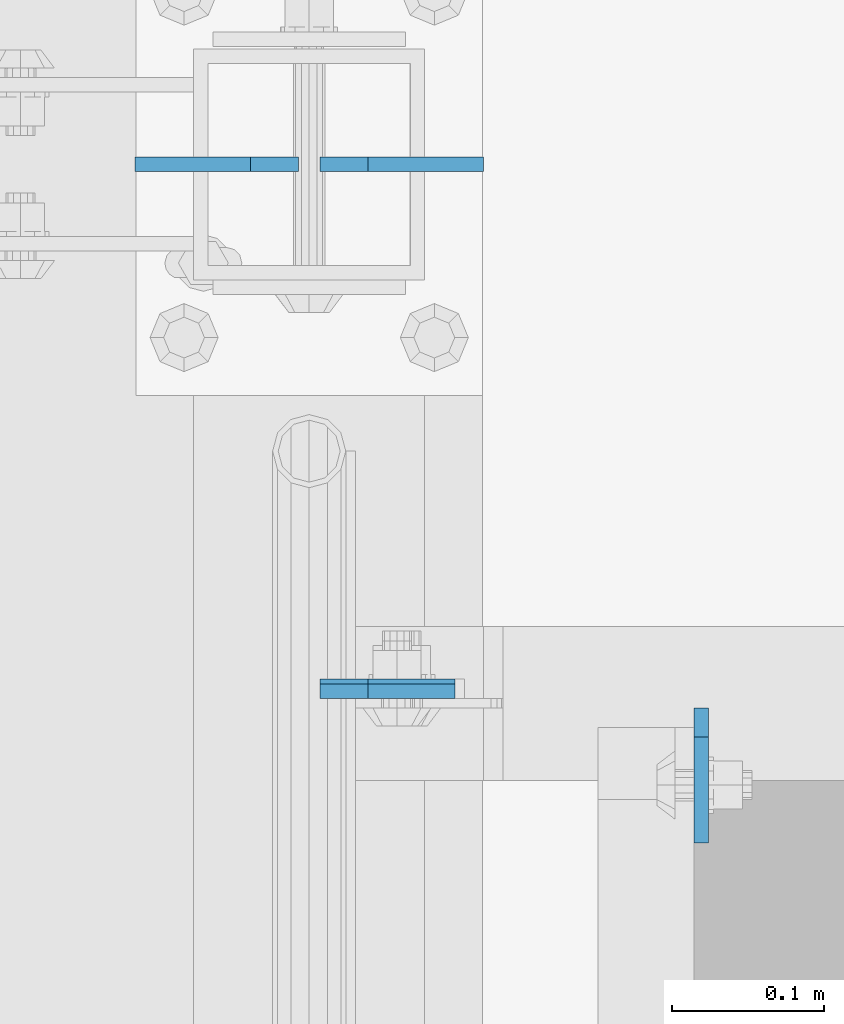
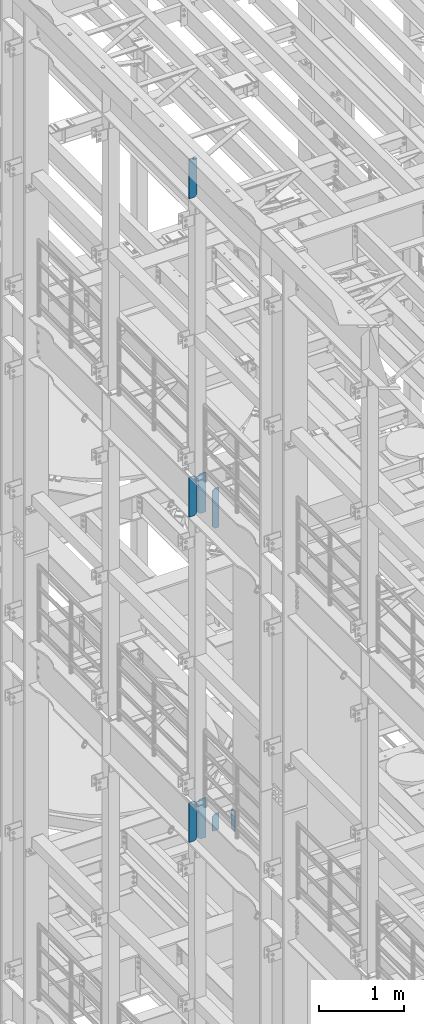
# One storey, part 1600 of 1876: 8 plates, 4 elements without a shape of their own.
"""IFC2X3 building model written with IfcOpenShell, lengths in millimetres."""

import ifcopenshell
import ifcopenshell.guid

model = None  # the IFC model being written
_history = None  # IfcOwnerHistory: only IFC2X3 demands one
_inside = {}  # id of a spatial element -> (the spatial element, [elements in it])
_under = {}  # id of a project, library or spatial element -> (it, [spatial elements below it])
_declared = {}  # id of a project -> (the project, [libraries it declares])
_typed = {}  # id of a type object -> (the type object, [elements of that type])
_made_of = {}  # id of a material, layer set ... -> (it, [elements and type objects made of it])


def new_model(schema):
    """Start an empty IFC model of exactly this schema.

    Asked for "IFC4X3", IfcOpenShell would pick the latest addendum, in which some entities
    have other attributes; the version numbers below select the first issue.
    IFC2X3 requires an IfcOwnerHistory on every rooted entity: one is made here for all.
    """
    global model, _history
    if schema == "IFC4X3":
        model = ifcopenshell.file(schema_version=(4, 3, 0, 0))
    else:
        model = ifcopenshell.file(schema=schema)
    _inside.clear()
    _under.clear()
    _declared.clear()
    _typed.clear()
    _made_of.clear()
    _history = None
    if model.schema == "IFC2X3":
        org = make("IfcOrganization", Name="unknown")
        user = make(
            "IfcPersonAndOrganization",
            ThePerson=make("IfcPerson", FamilyName="unknown"),
            TheOrganization=org,
        )
        app = make(
            "IfcApplication",
            ApplicationDeveloper=org,
            Version="unknown",
            ApplicationFullName="unknown",
            ApplicationIdentifier="unknown",
        )
        _history = make(
            "IfcOwnerHistory",
            OwningUser=user,
            OwningApplication=app,
            ChangeAction="ADDED",
            CreationDate=0,
        )
    return model


def make(cls, **values):
    """One entity of the class cls with the attributes given. An attribute that is None is left unset."""
    return model.create_entity(
        cls, **{name: value for name, value in values.items() if value is not None}
    )


def rooted(cls, **values):
    """An entity with a GlobalId (a new one), such as an element, a storey or a relation."""
    return make(cls, GlobalId=ifcopenshell.guid.new(), OwnerHistory=_history, **values)


def si_unit(unit_type, name, prefix=None):
    """IfcSIUnit, for example si_unit("LENGTHUNIT", "METRE", prefix="MILLI")."""
    return make("IfcSIUnit", UnitType=unit_type, Prefix=prefix, Name=name)


def assignment(units):
    """IfcUnitAssignment: the units of a project."""
    return None if units is None else make("IfcUnitAssignment", Units=units)


def point(xyz):
    """IfcCartesianPoint."""
    return None if xyz is None else make("IfcCartesianPoint", Coordinates=xyz)


def direction(xyz):
    """IfcDirection."""
    return None if xyz is None else make("IfcDirection", DirectionRatios=xyz)


def frame(location, z_axis=None, x_axis=None):
    """IfcAxis2Placement3D, a coordinate frame: its origin and axes. An axis left out is left unset."""
    return make(
        "IfcAxis2Placement3D",
        Location=point(location),
        Axis=direction(z_axis),
        RefDirection=direction(x_axis),
    )


def origin_with_axes():
    """The frame at (0, 0, 0) with the z axis (0, 0, 1) and the x axis (1, 0, 0) written out."""
    return frame((0.0, 0.0, 0.0), z_axis=(0.0, 0.0, 1.0), x_axis=(1.0, 0.0, 0.0))


def place(relative_to, where):
    """IfcLocalPlacement: puts the frame where relative to a parent placement (None: the world)."""
    return make(
        "IfcLocalPlacement", PlacementRelTo=relative_to, RelativePlacement=where
    )


def context(
    kind, dimensions, precision=None, world=None, true_north=None, identifier=None
):
    """IfcGeometricRepresentationContext, for example the 3D "Model" context."""
    return make(
        "IfcGeometricRepresentationContext",
        ContextIdentifier=identifier,
        ContextType=kind,
        CoordinateSpaceDimension=dimensions,
        Precision=precision,
        WorldCoordinateSystem=world,
        TrueNorth=true_north,
    )


def subcontext(parent, identifier, kind, view, scale=None):
    """IfcGeometricRepresentationSubContext, for example "Body" below "Model"."""
    return make(
        "IfcGeometricRepresentationSubContext",
        ContextIdentifier=identifier,
        ContextType=kind,
        ParentContext=parent,
        TargetScale=scale,
        TargetView=view,
    )


def project(units=None, contexts=None):
    """IfcProject with its units and contexts."""
    return rooted(
        "IfcProject",
        Name="project",
        RepresentationContexts=contexts,
        UnitsInContext=assignment(units),
    )


def spatial(cls, under=None, at=None, **own):
    """A site, building, storey or space (cls), placed at a placement, below another one or the project."""
    s = rooted(cls, ObjectPlacement=at, **own)
    if under is not None:
        _under.setdefault(under.id(), (under, []))[1].append(s)
    return s


def faces_of(points, faces, orient=None, outer=None):
    """IfcFace entities. A face is a list of loops; a loop is a list of indices into points, from 0.

    orient and outer hold one flag for each loop. By default every Orientation is true, the
    first loop of a face is its IfcFaceOuterBound and the others are IfcFaceBound.
    """
    made = []
    for i, loops in enumerate(faces):
        bounds = []
        for j, loop in enumerate(loops):
            is_outer = j == 0 if outer is None else outer[i][j]
            bounds.append(
                make(
                    "IfcFaceOuterBound" if is_outer else "IfcFaceBound",
                    Bound=make("IfcPolyLoop", Polygon=[points[k] for k in loop]),
                    Orientation=True if orient is None else orient[i][j],
                )
            )
        made.append(make("IfcFace", Bounds=bounds))
    return made


def faceted_brep(points, faces, orient=None, outer=None, voids=None):
    """IfcFacetedBrep: a solid bounded by flat faces; with voids (closed shells), ...WithVoids."""
    shared = [point(p) for p in points]
    hull = make("IfcClosedShell", CfsFaces=faces_of(shared, faces, orient, outer))
    if voids is None:
        return make("IfcFacetedBrep", Outer=hull)
    return make(
        "IfcFacetedBrepWithVoids",
        Outer=hull,
        Voids=[
            make(cls, CfsFaces=faces_of(shared, fs, o, b)) for cls, fs, o, b in voids
        ],
    )


def shape(context_of_items, identifier, shape_type, items):
    """IfcShapeRepresentation: the items that make up one representation, for example the "Body"."""
    return make(
        "IfcShapeRepresentation",
        ContextOfItems=context_of_items,
        RepresentationIdentifier=identifier,
        RepresentationType=shape_type,
        Items=items,
    )


def material(Name=None, Category=None):
    """IfcMaterial."""
    return make("IfcMaterial", Name=Name, Category=Category)


def made_of(thing, what):
    """Note that an element or type object is made of a material, layer set ...; save() writes the relation."""
    if what is not None:
        _made_of.setdefault(what.id(), (what, []))[1].append(thing)
    return thing


def type_object(cls, material=None, **own):
    """A type object (cls), such as IfcWallType, which elements share."""
    return made_of(rooted(cls, **own), material)


def element(
    cls,
    number,
    at=None,
    inside=None,
    cuts=None,
    type_object=None,
    material=None,
    context=None,
    identifier="Body",
    shape_type=None,
    held_by="IfcProductDefinitionShape",
    body=None,
    shapes=None,
    **own,
):
    """One element of the class cls, such as IfcWall. Its Tag is "e" and its number.

    at: its placement. inside: the storey or other place that contains it. cuts: it is an
    opening in that element (IfcRelVoidsElement). A single representation is given by context,
    identifier, shape_type and body (its items); several are given by shapes. held_by: the class
    of the entity that holds the representations. save() writes the other relations.
    """
    e = rooted(cls, Tag="e%d" % number, ObjectPlacement=at, **own)
    if body is not None:
        shapes = [shape(context, identifier, shape_type, body)]
    if shapes is not None:
        e.Representation = make(held_by, Representations=shapes)
    if inside is not None:
        _inside.setdefault(inside.id(), (inside, []))[1].append(e)
    if cuts is not None:
        rooted(
            "IfcRelVoidsElement", RelatingBuildingElement=cuts, RelatedOpeningElement=e
        )
    if type_object is not None:
        _typed.setdefault(type_object.id(), (type_object, []))[1].append(e)
    return made_of(e, material)


def aggregate(whole, parts):
    """IfcRelAggregates: a whole, such as a stair, and the parts it consists of."""
    return rooted("IfcRelAggregates", RelatingObject=whole, RelatedObjects=parts)


def save(model, path):
    """Write the relations noted so far, then the file.

    IfcRelAggregates (storeys below a building ...), IfcRelContainedInSpatialStructure (elements
    in a storey), IfcRelDefinesByType, IfcRelAssociatesMaterial and IfcRelDeclares: one each for
    every whole, place, type object, material and project.
    """
    for whole, parts in _under.values():
        aggregate(whole, parts)
    for where, things in _inside.values():
        rooted(
            "IfcRelContainedInSpatialStructure",
            RelatedElements=things,
            RelatingStructure=where,
        )
    for kind, things in _typed.values():
        rooted("IfcRelDefinesByType", RelatedObjects=things, RelatingType=kind)
    for what, things in _made_of.values():
        rooted("IfcRelAssociatesMaterial", RelatedObjects=things, RelatingMaterial=what)
    for by, libraries in _declared.values():
        rooted("IfcRelDeclares", RelatingContext=by, RelatedDefinitions=libraries)
    model.write(path)


model = new_model("IFC2X3")

# Units and contexts
model_context = context("Model", 3, precision=1e-05, world=origin_with_axes())
body_context = subcontext(model_context, "Body", "Model", "MODEL_VIEW")
ifc_project = project(units=[si_unit("LENGTHUNIT", "METRE", prefix="MILLI"), si_unit("AREAUNIT", "SQUARE_METRE"), si_unit("VOLUMEUNIT", "CUBIC_METRE"), si_unit("MASSUNIT", "GRAM", prefix="KILO"), si_unit("TIMEUNIT", "SECOND"), si_unit("PLANEANGLEUNIT", "RADIAN"), si_unit("SOLIDANGLEUNIT", "STERADIAN"), si_unit("THERMODYNAMICTEMPERATUREUNIT", "DEGREE_CELSIUS"), si_unit("LUMINOUSINTENSITYUNIT", "LUMEN")], contexts=[model_context])

# Site, building, storey
site_placement = place(None, origin_with_axes())
site = spatial("IfcSite", under=ifc_project, at=site_placement, CompositionType="ELEMENT")
building_placement = place(site_placement, origin_with_axes())
building = spatial("IfcBuilding", under=site, at=building_placement, Name="Undefined", CompositionType="ELEMENT")
storey_placement = place(building_placement, origin_with_axes())
storey = spatial("IfcBuildingStorey", under=building, at=storey_placement, Name="Undefined", CompositionType="ELEMENT", Elevation=0.0)

# Assembly, plate
assembly_1_placement = place(storey_placement, origin_with_axes())
assembly_1 = element("IfcElementAssembly", 1, at=assembly_1_placement, inside=storey, Name="BEAM", AssemblyPlace="NOTDEFINED", PredefinedType="RIGID_FRAME")
ifc_material = material(Name="STEEL/A36")
plate_type_1 = type_object("IfcPlateType", PredefinedType="NOTDEFINED")
plate_1_placement = place(assembly_1_placement, frame((258.762999916077, 3197.225, 13012.7375), z_axis=(0.0, 0.0, 1.0), x_axis=(0.0, -1.0, 0.0)))
plate_1 = element("IfcPlate", 2, at=plate_1_placement, type_object=plate_type_1, material=ifc_material, Name="PLATE", context=body_context, shape_type="Brep", body=[
    faceted_brep([(0.0, -4.76249999999982, 19.0499992370605), (0.0, -4.76249999999982, 271.462512969971), (0.0, 4.76249999999982, 271.462512969971), (0.0, 4.76249999999982, 19.0499992370605), (19.0499992370605, -4.76249999999982, 290.512512207031), (19.0499992370605, 4.76249999999982, 290.512512207031), (88.9000015258789, -4.76249999999982, 290.512512207031), (88.9000015258789, 4.76249999999982, 290.512512207031), (88.9000015258789, -4.76249999999982, 0.0), (88.9000015258789, 4.76249999999982, 0.0), (19.0499992370605, -4.76249999999982, 0.0), (19.0499992370605, 4.76249999999982, 0.0)], [[[0, 1, 2, 3]], [[1, 4, 5, 2]], [[4, 6, 7, 5]], [[6, 8, 9, 7]], [[8, 10, 11, 9]], [[10, 0, 3, 11]], [[5, 7, 9, 11, 3, 2]], [[10, 8, 6, 4, 1, 0]]]),
])
aggregate(assembly_1, [plate_1])

assembly_2_placement = place(storey_placement, origin_with_axes())
assembly_2 = element("IfcElementAssembly", 3, at=assembly_2_placement, inside=storey, Name="BEAM", AssemblyPlace="NOTDEFINED", PredefinedType="RIGID_FRAME")
plate_2_placement = place(assembly_2_placement, frame((7.14375000000001, 3208.33799991608, 13042.9), z_axis=(0.0, 0.0, 1.0), x_axis=(1.0, 0.0, 0.0)))
plate_2 = element("IfcPlate", 4, at=plate_2_placement, type_object=plate_type_1, material=ifc_material, Name="PLATE", context=body_context, shape_type="Brep", body=[
    faceted_brep([(0.0, -4.76249999999982, 0.0), (0.0, -4.76249999999982, 209.550003051758), (0.0, 4.76249999999982, 209.550003051758), (0.0, 4.76249999999982, 0.0), (31.75, -4.76249999999982, 241.300003051758), (31.75, 4.76249999999982, 241.300003051758), (88.9000015258788, -4.76249999999982, 241.300003051758), (88.9000015258788, 4.76249999999982, 241.300003051758), (88.9000015258789, -4.76249999999982, 0.0), (88.9000015258789, 4.76249999999982, 0.0)], [[[0, 1, 2, 3]], [[1, 4, 5, 2]], [[4, 6, 7, 5]], [[6, 8, 9, 7]], [[8, 0, 3, 9]], [[5, 7, 9, 3, 2]], [[8, 6, 4, 1, 0]]]),
])

assembly_3_placement = place(storey_placement, origin_with_axes())
assembly_3 = element("IfcElementAssembly", 5, at=assembly_3_placement, inside=storey, Name="BEAM", AssemblyPlace="NOTDEFINED", PredefinedType="RIGID_FRAME")
plate_type_2 = type_object("IfcPlateType", PredefinedType="NOTDEFINED")
plate_3_placement = place(assembly_3_placement, frame((7.14375000000001, 3209.92500009537, 17386.3), z_axis=(0.0, 0.0, 1.0), x_axis=(1.0, 0.0, 0.0)))
plate_3 = element("IfcPlate", 6, at=plate_3_placement, type_object=plate_type_2, material=ifc_material, Name="PLATE", context=body_context, shape_type="Brep", body=[
    faceted_brep([(0.0, -6.34999999999991, 31.75), (0.0, -6.34999999999991, 539.75), (0.0, 6.34999999999991, 539.75), (0.0, 6.34999999999991, 31.75), (31.75, -6.34999999999991, 571.5), (31.75, 6.34999999999991, 571.5), (88.9000015258789, -6.34999999999991, 571.5), (88.9000015258789, 6.34999999999991, 571.5), (88.9000015258789, -6.34999999999991, 0.0), (88.9000015258789, 6.34999999999991, 0.0), (31.75, -6.34999999999991, 0.0), (31.75, 6.34999999999991, 0.0)], [[[0, 1, 2, 3]], [[1, 4, 5, 2]], [[4, 6, 7, 5]], [[6, 8, 9, 7]], [[8, 10, 11, 9]], [[10, 0, 3, 11]], [[5, 7, 9, 11, 3, 2]], [[10, 8, 6, 4, 1, 0]]]),
])

assembly_4_placement = place(storey_placement, origin_with_axes())
assembly_4 = element("IfcElementAssembly", 7, at=assembly_4_placement, inside=storey, Name="BEAM", AssemblyPlace="NOTDEFINED", PredefinedType="RIGID_FRAME")
plate_type_3 = type_object("IfcPlateType", PredefinedType="NOTDEFINED")
plate_4_placement = place(assembly_4_placement, frame((-7.14374915193636, 3555.9999999841, 21958.3), z_axis=(0.0, 0.0, 1.0), x_axis=(-1.0, 0.0, 0.0)))
plate_4 = element("IfcPlate", 8, at=plate_4_placement, type_object=plate_type_3, material=ifc_material, Name="PLATE", context=body_context, shape_type="Brep", body=[
    faceted_brep([(-9.76996261670138e-14, -4.76250000000073, 31.75), (0.0, -4.76249999999982, 539.75), (0.0, 4.76249999999982, 539.75), (-9.76996261670138e-14, 4.76250000000073, 31.75), (31.75, -4.76249999999982, 571.5), (31.75, 4.76249999999982, 571.5), (107.949996948242, -4.76249999999982, 571.5), (107.949996948242, 4.76249999999982, 571.5), (107.950006484985, -4.76250000000073, 0.0), (107.950006484985, 4.76250000000073, 0.0), (31.75, -4.76250000000073, 0.0), (31.75, 4.76250000000073, 0.0)], [[[0, 1, 2, 3]], [[1, 4, 5, 2]], [[4, 6, 7, 5]], [[6, 8, 9, 7]], [[8, 10, 11, 9]], [[10, 0, 3, 11]], [[5, 7, 9, 11, 3, 2]], [[10, 8, 6, 4, 1, 0]]]),
])
aggregate(assembly_4, [plate_4])

# Plate
plate_5_placement = place(assembly_3_placement, frame((115.093750848064, 3556.00000025619, 17386.3), z_axis=(0.0, 0.0, 1.0), x_axis=(-1.0, 0.0, 0.0)))
plate_5 = element("IfcPlate", 9, at=plate_5_placement, type_object=plate_type_3, material=ifc_material, Name="PLATE", context=body_context, shape_type="Brep", body=[
    faceted_brep([(0.0, -4.76249999999982, 0.0), (0.0, -4.76249999999982, 571.5), (0.0, 4.76249999999982, 571.5), (0.0, 4.76249999999982, 0.0), (76.1999969482422, -4.76249999999982, 571.5), (76.1999969482422, 4.76249999999982, 571.5), (107.949996948242, -4.76249999999982, 539.75), (107.949996948242, 4.76249999999982, 539.75), (107.949996948242, -4.76249999999982, 31.75), (107.949996948242, 4.76249999999982, 31.75), (76.1999969482422, -4.76250000000073, 0.0), (76.1999969482422, 4.76250000000073, 0.0)], [[[0, 1, 2, 3]], [[1, 4, 5, 2]], [[4, 6, 7, 5]], [[6, 8, 9, 7]], [[8, 10, 11, 9]], [[10, 0, 3, 11]], [[5, 7, 9, 11, 3, 2]], [[10, 8, 6, 4, 1, 0]]]),
])

plate_6_placement = place(assembly_3_placement, frame((-7.14374915193636, 3556.00000025619, 17386.3), z_axis=(0.0, 0.0, 1.0), x_axis=(-1.0, 0.0, 0.0)))
plate_6 = element("IfcPlate", 10, at=plate_6_placement, type_object=plate_type_3, material=ifc_material, Name="PLATE", context=body_context, shape_type="Brep", body=[
    faceted_brep([(-9.76996261670138e-14, -4.76250000000073, 31.75), (0.0, -4.76249999999982, 539.75), (0.0, 4.76249999999982, 539.75), (-9.76996261670138e-14, 4.76250000000073, 31.75), (31.75, -4.76249999999982, 571.5), (31.75, 4.76249999999982, 571.5), (107.949996948242, -4.76249999999982, 571.5), (107.949996948242, 4.76249999999982, 571.5), (107.950006484985, -4.76250000000073, 0.0), (107.950006484985, 4.76250000000073, 0.0), (31.75, -4.76250000000073, 0.0), (31.75, 4.76250000000073, 0.0)], [[[0, 1, 2, 3]], [[1, 4, 5, 2]], [[4, 6, 7, 5]], [[6, 8, 9, 7]], [[8, 10, 11, 9]], [[10, 0, 3, 11]], [[5, 7, 9, 11, 3, 2]], [[10, 8, 6, 4, 1, 0]]]),
])

aggregate(assembly_3, [plate_3, plate_5, plate_6])

plate_7_placement = place(assembly_2_placement, frame((115.093750848064, 3556.00000025619, 12712.7), z_axis=(0.0, 0.0, 1.0), x_axis=(-1.0, 0.0, 0.0)))
plate_7 = element("IfcPlate", 11, at=plate_7_placement, type_object=plate_type_3, material=ifc_material, Name="PLATE", context=body_context, shape_type="Brep", body=[
    faceted_brep([(0.0, -4.76249999999982, 0.0), (0.0, -4.76249999999982, 571.5), (0.0, 4.76249999999982, 571.5), (0.0, 4.76249999999982, 0.0), (76.1999969482422, -4.76249999999982, 571.5), (76.1999969482422, 4.76249999999982, 571.5), (107.949996948242, -4.76249999999982, 539.75), (107.949996948242, 4.76249999999982, 539.75), (107.949996948242, -4.76249999999982, 31.75), (107.949996948242, 4.76249999999982, 31.75), (76.1999969482422, -4.76250000000073, 0.0), (76.1999969482422, 4.76250000000073, 0.0)], [[[0, 1, 2, 3]], [[1, 4, 5, 2]], [[4, 6, 7, 5]], [[6, 8, 9, 7]], [[8, 10, 11, 9]], [[10, 0, 3, 11]], [[5, 7, 9, 11, 3, 2]], [[10, 8, 6, 4, 1, 0]]]),
])

plate_8_placement = place(assembly_2_placement, frame((-7.14374915193636, 3556.00000025619, 12712.7), z_axis=(0.0, 0.0, 1.0), x_axis=(-1.0, 0.0, 0.0)))
plate_8 = element("IfcPlate", 12, at=plate_8_placement, type_object=plate_type_3, material=ifc_material, Name="PLATE", context=body_context, shape_type="Brep", body=[
    faceted_brep([(-9.76996261670138e-14, -4.76250000000073, 31.75), (0.0, -4.76249999999982, 539.75), (0.0, 4.76249999999982, 539.75), (-9.76996261670138e-14, 4.76250000000073, 31.75), (31.75, -4.76249999999982, 571.5), (31.75, 4.76249999999982, 571.5), (107.949996948242, -4.76249999999982, 571.5), (107.949996948242, 4.76249999999982, 571.5), (107.950006484985, -4.76250000000073, 0.0), (107.950006484985, 4.76250000000073, 0.0), (31.75, -4.76250000000073, 0.0), (31.75, 4.76250000000073, 0.0)], [[[0, 1, 2, 3]], [[1, 4, 5, 2]], [[4, 6, 7, 5]], [[6, 8, 9, 7]], [[8, 10, 11, 9]], [[10, 0, 3, 11]], [[5, 7, 9, 11, 3, 2]], [[10, 8, 6, 4, 1, 0]]]),
])

aggregate(assembly_2, [plate_2, plate_7, plate_8])

save(model, "model.ifc")
